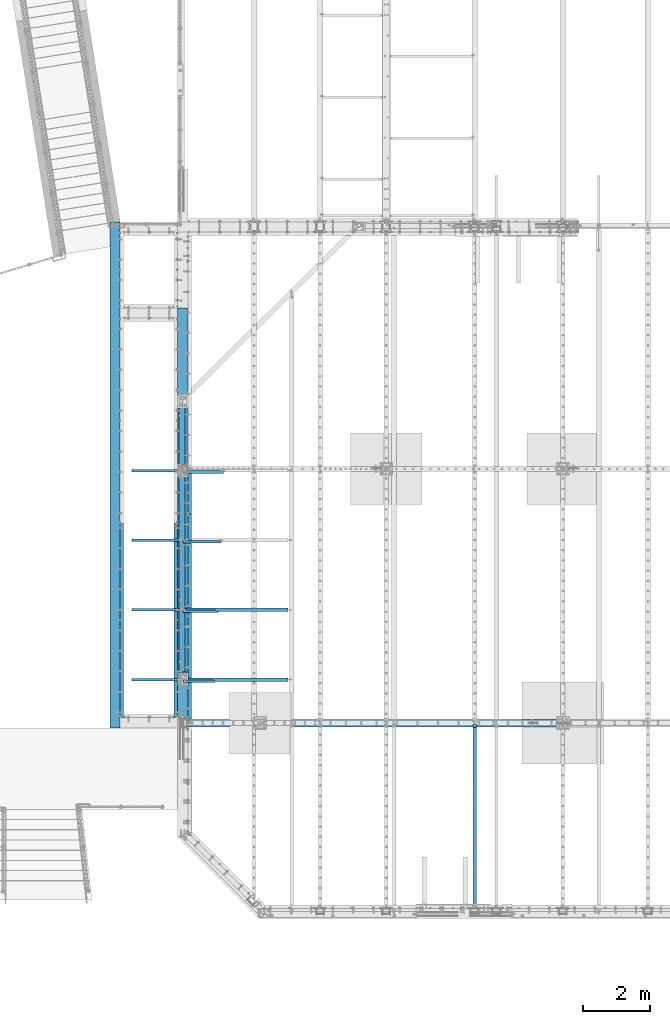
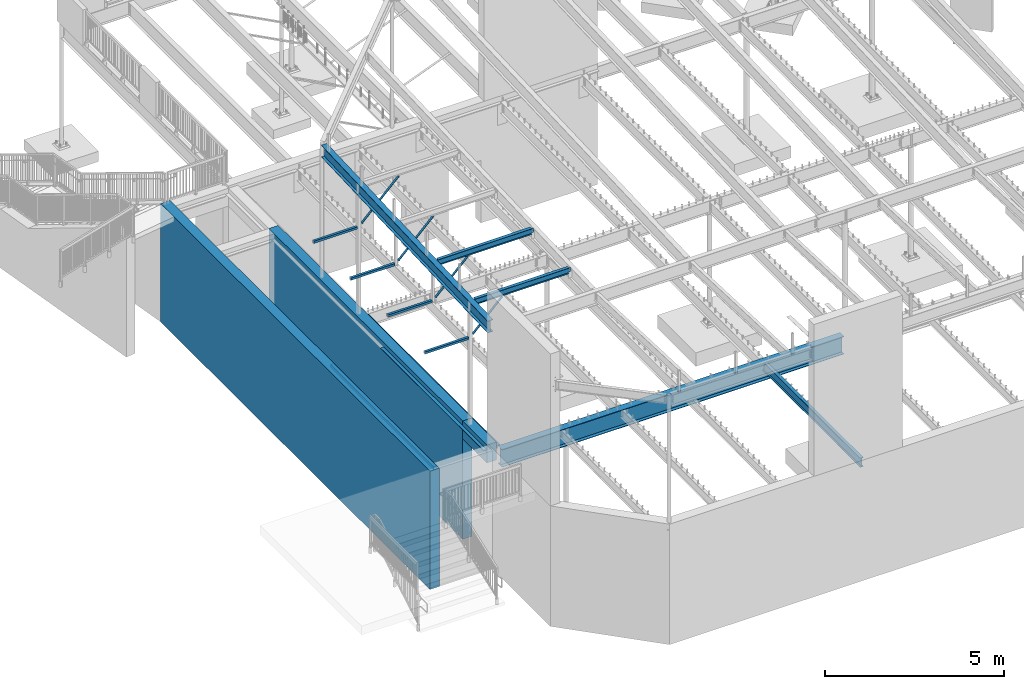
# One storey, part 311 of 975: 16 beams, 4 members.
"""IFC2X3 building model written with IfcOpenShell, lengths in millimetres."""

from ifc_helpers import new_model, si_unit, frame, origin_with_axes, place, context, subcontext, project, spatial, faceted_brep, material, type_object, element, save


model = new_model("IFC2X3")

# Units and contexts
model_context = context("Model", 3, precision=1e-05, world=origin_with_axes())
body_context = subcontext(model_context, "Body", "Model", "MODEL_VIEW")
ifc_project = project(units=[si_unit("LENGTHUNIT", "METRE", prefix="MILLI"), si_unit("AREAUNIT", "SQUARE_METRE"), si_unit("VOLUMEUNIT", "CUBIC_METRE"), si_unit("MASSUNIT", "GRAM", prefix="KILO"), si_unit("TIMEUNIT", "SECOND"), si_unit("PLANEANGLEUNIT", "RADIAN"), si_unit("SOLIDANGLEUNIT", "STERADIAN"), si_unit("THERMODYNAMICTEMPERATUREUNIT", "DEGREE_CELSIUS"), si_unit("LUMINOUSINTENSITYUNIT", "LUMEN")], contexts=[model_context])

# Site, building, storey
site_placement = place(None, origin_with_axes())
site = spatial("IfcSite", under=ifc_project, at=site_placement, CompositionType="ELEMENT")
building_placement = place(site_placement, origin_with_axes())
building = spatial("IfcBuilding", under=site, at=building_placement, Name="Undefined", CompositionType="ELEMENT")
storey_placement = place(building_placement, origin_with_axes())
storey = spatial("IfcBuildingStorey", under=building, at=storey_placement, Name="Undefined", CompositionType="ELEMENT", Elevation=0.0)

# Beams
ifc_material_1 = material(Name="CONCRETE/5000")
beam_type_1 = type_object("IfcBeamType", PredefinedType="NOTDEFINED")
beam_1_placement = place(storey_placement, frame((152.400000017972, 20748.6250000414, 2019.3), z_axis=(0.0, 0.0, 1.0), x_axis=(0.0, -1.0, 0.0)))
element("IfcBeam", 1, at=beam_1_placement, inside=storey, type_object=beam_type_1, material=ifc_material_1, Name="WALL", context=body_context, shape_type="Brep", body=[
    faceted_brep([(0.0, 152.4, -2019.3), (0.0, 152.4, 2019.3), (15072.8519383796, 152.4, 2019.3), (15072.8519383796, 152.4, -2019.3), (0.0, -152.4, 2019.3), (15072.8519383796, -152.4, 2019.3), (0.0, -152.4, -2019.3), (15072.8519383796, -152.4, -2019.3)], [[[0, 1, 2, 3]], [[1, 4, 5, 2]], [[4, 6, 7, 5]], [[6, 0, 3, 7]], [[5, 7, 3, 2]], [[6, 4, 1, 0]]]),
])
beam_2_placement = place(storey_placement, frame((2168.525, 18183.225, 2019.3), z_axis=(0.0, 0.0, 1.0), x_axis=(0.0, -1.0, 0.0)))
element("IfcBeam", 2, at=beam_2_placement, inside=storey, type_object=beam_type_1, material=ifc_material_1, Name="WALL", context=body_context, shape_type="Brep", body=[
    faceted_brep([(0.0, 152.4, -2019.3), (0.0, 152.4, 2019.3), (10839.45, 152.4, 2019.3), (10839.45, 152.4, -2019.3), (0.0, -152.4, 2019.3), (10839.45, -152.4, 2019.3), (0.0, -152.4, -2019.3), (10839.45, -152.4, -2019.3)], [[[0, 1, 2, 3]], [[1, 4, 5, 2]], [[4, 6, 7, 5]], [[6, 0, 3, 7]], [[5, 7, 3, 2]], [[6, 4, 1, 0]]]),
])
ifc_material_2 = material(Name="STEEL/A36")
beam_type_2 = type_object("IfcBeamType", Name="L4X4X5/16", PredefinedType="NOTDEFINED")
for number, where, z_axis, x_axis, name in (
    (3, (355.60003007098, 5994.39980505361, 3835.4), (1.0, 0.0, 0.0), (0.0, 1.0, 0.0), "LEDGER_ANGLE"),
    (4, (1965.32501154889, 11769.7250003556, 3835.4), (-0.999999999999998, 6.90000001668524e-08, 0.0), (0.0, -1.0, 0.0), "LEDGER_ANGLE"),
):
    element("IfcBeam", number, at=place(storey_placement, frame(where, z_axis=z_axis, x_axis=x_axis)), inside=storey, type_object=beam_type_2, material=ifc_material_2, Name=name, ObjectType="L4X4X5/16", context=body_context, shape_type="Brep", body=[
        faceted_brep([(-1.90993887372315e-11, 50.8000000000002, -50.8), (2.00088834390044e-11, 50.8000000000002, 50.8), (5775.32519530204, 50.8000000000002, 50.8000000000993), (5775.325195302, 50.8000000000002, -50.7999999999008), (2.00088834390044e-11, 42.8625000000002, 50.8), (5775.32519530204, 42.8625000000002, 50.8000000000993), (-1.63709046319127e-11, 42.8625000000002, -42.8625), (5775.325195302, 42.8625000000002, -42.8624999999008), (-1.63709046319127e-11, -50.8000000000002, -42.8625), (5775.325195302, -50.8000000000002, -42.8624999999008), (-1.90993887372315e-11, -50.8000000000002, -50.8), (5775.325195302, -50.8000000000002, -50.7999999999008)], [[[0, 1, 2, 3]], [[1, 4, 5, 2]], [[4, 6, 7, 5]], [[6, 8, 9, 7]], [[8, 10, 11, 9]], [[10, 0, 3, 11]], [[5, 7, 9, 11, 3, 2]], [[10, 8, 6, 4, 1, 0]]]),
    ])
beam_3_placement = place(storey_placement, frame((2371.72537068116, 12042.7750061875, 3886.2), z_axis=(1.0, 0.0, 0.0), x_axis=(0.0, 1.0, 0.0)))
element("IfcBeam", 5, at=beam_3_placement, inside=storey, type_object=beam_type_2, material=ifc_material_2, Name="LEDGER_ANGLE", ObjectType="L4X4X5/16", context=body_context, shape_type="Brep", body=[
    faceted_brep([(-1.90993887372315e-11, 50.8000000000002, -50.8), (2.00088834390044e-11, 50.8000000000002, 50.8), (1260.4749999992, 50.8000000000002, 50.7999999999065), (1260.47499999924, 50.8000000000002, -50.8000000000939), (2.00088834390044e-11, 42.8625000000002, 50.8), (1260.4749999992, 42.8625000000002, 50.7999999999065), (-1.63709046319127e-11, 42.8625000000002, -42.8625), (1260.47499999924, 42.8625000000002, -42.8625000000939), (-1.63709046319127e-11, -50.8000000000002, -42.8625), (1260.47499999924, -50.8000000000002, -42.8625000000939), (-1.90993887372315e-11, -50.8000000000002, -50.8), (1260.47499999924, -50.8000000000002, -50.8000000000939)], [[[0, 1, 2, 3]], [[1, 4, 5, 2]], [[4, 6, 7, 5]], [[6, 8, 9, 7]], [[8, 10, 11, 9]], [[10, 0, 3, 11]], [[5, 7, 9, 11, 3, 2]], [[10, 8, 6, 4, 1, 0]]]),
])
beam_4_placement = place(storey_placement, frame((2371.72501101716, 5946.77499700093, 3886.2), z_axis=(1.0, 0.0, 0.0), x_axis=(0.0, 1.0, 0.0)))
element("IfcBeam", 6, at=beam_4_placement, inside=storey, type_object=beam_type_2, material=ifc_material_2, Name="LEDGER_ANGLE", ObjectType="L4X4X5/16", context=body_context, shape_type="Brep", body=[
    faceted_brep([(-1.90993887372315e-11, 50.8000000000002, -50.8), (2.00088834390044e-11, 50.8000000000002, 50.8), (6095.99999999997, 50.8000000000002, 50.8000000001048), (6096.00000000003, 50.8000000000002, -50.7999999998952), (2.00088834390044e-11, 42.8625000000002, 50.8), (6095.99999999997, 42.8625000000002, 50.8000000001048), (-1.63709046319127e-11, 42.8625000000002, -42.8625), (6096.00000000003, 42.8625000000002, -42.8624999998952), (-1.63709046319127e-11, -50.8000000000002, -42.8625), (6096.00000000003, -50.8000000000002, -42.8624999998952), (-1.90993887372315e-11, -50.8000000000002, -50.8), (6096.00000000003, -50.8000000000002, -50.7999999998952)], [[[0, 1, 2, 3]], [[1, 4, 5, 2]], [[4, 6, 7, 5]], [[6, 8, 9, 7]], [[8, 10, 11, 9]], [[10, 0, 3, 11]], [[5, 7, 9, 11, 3, 2]], [[10, 8, 6, 4, 1, 0]]]),
])
ifc_material_3 = material(Name="STEEL/A992")
beam_type_3 = type_object("IfcBeamType", Name="W8X10", PredefinedType="NOTDEFINED")
beam_5_placement = place(storey_placement, frame((2143.16873967635, 7115.17500010167, 8181.14825487244), z_axis=(0.00043655899987343, 0.0, -0.999999904708115), x_axis=(0.999999904708115, 0.0, 0.000436558999873341)))
element("IfcBeam", 7, at=beam_5_placement, inside=storey, type_object=beam_type_3, material=ifc_material_3, Name="BEAM", ObjectType="W8X10", context=body_context, shape_type="Brep", body=[
    faceted_brep([(3152.68790786515, -2.38125000000036, -95.2500000011923), (3152.68790786515, -50.8000000000002, -95.2500000011923), (3152.68790786516, -50.8000000000002, -100.012499998263), (3152.68790786516, 50.8000000000002, -100.012500001189), (3152.68790786515, 50.8000000000002, -95.2500000011923), (3152.68790786515, 2.38125000000036, -95.2500000011923), (3152.68790786515, 2.38125000000036, -87.3124998263784), (3152.68790786515, -2.38125000000036, -87.3124998263784), (3153.65463778774, 2.38125000000036, -82.4524203083338), (3153.65463778774, -2.38125000000036, -82.4524203083338), (3156.40765168821, 2.38125000000036, -78.3322438401801), (3156.40765168821, -2.38125000000036, -78.3322438401801), (3160.52782815637, 2.38125000000036, -75.5792299397044), (3160.52782815637, -2.38125000000036, -75.5792299397044), (3165.38790767441, 2.38125000000036, -74.6125000171169), (3165.38790767441, -2.38125000000036, -74.6125000171169), (3241.66414198657, -2.38125000000036, -74.6125000170896), (3241.66414198657, 2.38125000000036, -74.6125000170896), (3152.68790786629, 50.8000000000002, 95.2499999987285), (3152.68790786629, 2.38125000000036, 95.2499999987285), (118.268769591082, 2.38125000000036, 95.2499999999136), (118.268769591082, 50.8000000000002, 95.2499999999136), (118.268769590937, -2.38125000000036, -87.312499810695), (118.268769590937, 2.38125000000036, -87.312499810695), (118.268769590941, 2.38125000000036, -95.2500000000064), (118.268769590941, 50.8000000000002, -95.2500000000064), (118.268769590944, 50.8000000000002, -100.012500000005), (118.268769590943, -50.8000000000002, -100.012499810899), (118.268769590941, -50.8000000000002, -95.2500000000064), (118.268769590941, -2.38125000000036, -95.2500000000064), (117.302039668346, -2.38125000000036, -82.4524202926505), (117.302039668346, 2.38125000000036, -82.4524202926505), (114.549025767866, -2.38125000000036, -78.3322438245004), (114.549025767866, 2.38125000000036, -78.3322438245004), (110.42884929971, -2.38125000000036, -75.5792299240211), (110.42884929971, 2.38125000000036, -75.5792299240211), (105.568769781664, -2.38125000000036, -74.6125000014354), (105.568769781664, 2.38125000000036, -74.6125000014354), (29.3576807630479, -2.38125000000036, -74.6125000014426), (29.3576807820982, 2.38125000000036, -74.6125000014426), (29.2925352400166, -2.38125000000036, 74.6124999982831), (29.2925352590664, 2.38125000000036, 74.612499998284), (105.568769781842, -2.38125000000036, 74.6124999982885), (105.568769781842, 2.38125000000036, 74.6124999982885), (110.428849299887, -2.38125000000036, 75.5792299208715), (110.428849299887, 2.38125000000036, 75.5792299208715), (114.54902576804, -2.38125000000036, 78.3322438213418), (114.54902576804, 2.38125000000036, 78.3322438213418), (117.302039668516, -2.38125000000036, 82.4524202894881), (117.302039668516, 2.38125000000036, 82.4524202894881), (118.268769591102, -2.38125000000036, 87.3124998075264), (118.268769591102, 2.38125000000036, 87.3124998075264), (3152.68790786629, -50.8000000000002, 100.012499998726), (3152.68790786629, 50.8000000000002, 100.012499998726), (118.268769591083, 50.8000000000002, 100.012499999913), (118.268769591084, -50.8000000000002, 100.012499999913), (3152.68790786629, -50.8000000000002, 95.2499999987285), (118.268769591082, -50.8000000000002, 95.2499999999136), (3152.68790786629, -2.38125000000036, 95.2499999987285), (118.268769591082, -2.38125000000036, 95.2499999999136), (3152.6879078663, -2.38125000000036, 87.3124997917321), (3152.6879078663, 2.38125000000036, 87.3124997917321), (3153.65463778889, -2.38125000000036, 82.4524202736911), (3153.65463778889, 2.38125000000036, 82.4524202736911), (3156.40765168937, -2.38125000000036, 78.3322438055402), (3156.40765168937, 2.38125000000036, 78.3322438055402), (3160.52782815752, -2.38125000000036, 75.5792299050618), (3160.52782815752, 2.38125000000036, 75.5792299050618), (3165.38790767556, -2.38125000000036, 74.6124999824715), (3165.38790767556, 2.38125000000036, 74.6124999824715), (3241.59899646353, -2.38125000000036, 74.6124999824424), (3241.59899646353, 2.38125000000036, 74.6124999824424)], [[[0, 1, 2, 3, 4, 5, 6, 7]], [[7, 6, 8, 9]], [[9, 8, 10, 11]], [[11, 10, 12, 13]], [[13, 12, 14, 15]], [[16, 15, 14, 17]], [[18, 19, 20, 21]], [[22, 23, 24, 25, 26, 27, 28, 29]], [[30, 31, 23, 22]], [[32, 33, 31, 30]], [[34, 35, 33, 32]], [[36, 37, 35, 34]], [[38, 39, 37, 36]], [[40, 41, 39, 38]], [[42, 43, 41, 40]], [[44, 45, 43, 42]], [[46, 47, 45, 44]], [[48, 49, 47, 46]], [[50, 51, 49, 48]], [[52, 53, 54, 55]], [[56, 52, 55, 57]], [[58, 56, 57, 59]], [[55, 54, 21, 20, 51, 50, 59, 57]], [[53, 18, 21, 54]], [[52, 56, 58, 60, 61, 19, 18, 53]], [[62, 63, 61, 60]], [[64, 65, 63, 62]], [[66, 67, 65, 64]], [[68, 69, 67, 66]], [[70, 71, 69, 68]], [[71, 70, 16, 17]], [[12, 10, 8, 6, 5, 24, 23, 31, 33, 35, 37, 39, 41, 43, 45, 47, 49, 51, 20, 19, 61, 63, 65, 67, 69, 71, 17, 14]], [[25, 24, 5, 4]], [[26, 25, 4, 3]], [[27, 26, 3, 2]], [[28, 27, 2, 1]], [[29, 28, 1, 0]], [[70, 68, 66, 64, 62, 60, 58, 59, 50, 48, 46, 44, 42, 40, 38, 36, 34, 32, 30, 22, 29, 0, 7, 9, 11, 13, 15, 16]]]),
])
beam_6_placement = place(storey_placement, frame((2143.23869058687, 9190.56666676833, 8263.7550268726), z_axis=(0.00113598099974151, 0.0, -0.999999354773376), x_axis=(0.999999354773376, 0.0, 0.00113598099974115)))
element("IfcBeam", 8, at=beam_6_placement, inside=storey, type_object=beam_type_3, material=ifc_material_3, Name="BEAM", ObjectType="W8X10", context=body_context, shape_type="Brep", body=[
    faceted_brep([(3152.54978858592, -2.38125000000036, -95.2499999995871), (3152.54978858592, -50.7999999999993, -95.2499999995871), (3152.54978858592, -50.7999999999993, -100.012499996652), (3152.54978858592, 50.7999999999993, -100.012499999588), (3152.54978858592, 50.7999999999993, -95.2499999995871), (3152.54978858592, 2.38125000000036, -95.2499999995871), (3152.54978858592, 2.38125000000036, -87.3124997948671), (3152.54978858592, -2.38125000000036, -87.3124997948671), (3153.51651850851, 2.38125000000036, -82.4524202768189), (3153.51651850851, -2.38125000000036, -82.4524202768189), (3156.26953240898, 2.38125000000036, -78.3322438086616), (3156.26953240898, -2.38125000000036, -78.3322438086616), (3160.38970887714, 2.38125000000036, -75.5792299081822), (3160.38970887714, -2.38125000000036, -75.5792299081822), (3165.24978839519, 2.38125000000036, -74.6124999855929), (3165.24978839519, -2.38125000000036, -74.6124999855929), (3241.44978858411, -2.38125000000036, -74.612499985582), (3241.44978858411, 2.38125000000036, -74.612499985582), (3152.54978858586, 50.7999999999993, 95.2500000004438), (3152.54978858586, 2.38125000000036, 95.2500000004438), (118.268769591082, 2.38125000000036, 95.2499999999136), (118.268769591082, 50.8000000000002, 95.2499999999136), (118.268769590937, -2.38125000000036, -87.312499810695), (118.268769590937, 2.38125000000036, -87.312499810695), (118.268769590941, 2.38125000000036, -95.2500000000064), (118.268769590941, 50.8000000000002, -95.2500000000064), (118.268769590944, 50.8000000000002, -100.012500000005), (118.268769590943, -50.8000000000002, -100.012499810899), (118.268769590941, -50.8000000000002, -95.2500000000064), (118.268769590941, -2.38125000000036, -95.2500000000064), (117.302039668346, -2.38125000000036, -82.4524202926505), (117.302039668346, 2.38125000000036, -82.4524202926505), (114.549025767866, -2.38125000000036, -78.3322438245004), (114.549025767866, 2.38125000000036, -78.3322438245004), (110.42884929971, -2.38125000000036, -75.5792299240211), (110.42884929971, 2.38125000000036, -75.5792299240211), (105.568769781664, -2.38125000000036, -74.6125000014354), (105.568769781664, 2.38125000000036, -74.6125000014354), (29.3687774666446, -2.38125000000036, -74.6125000038883), (29.3687774666446, 2.38125000000036, -74.6125000038883), (29.3687774666446, -2.38125000000036, 74.6124999961967), (29.3687774666446, 2.38125000000036, 74.6124999961967), (105.568769781842, -2.38125000000036, 74.6124999982885), (105.568769781842, 2.38125000000036, 74.6124999982885), (110.428849299887, -2.38125000000036, 75.5792299208715), (110.428849299887, 2.38125000000036, 75.5792299208715), (114.54902576804, -2.38125000000036, 78.3322438213418), (114.54902576804, 2.38125000000036, 78.3322438213418), (117.302039668516, -2.38125000000036, 82.4524202894881), (117.302039668516, 2.38125000000036, 82.4524202894881), (118.268769591102, -2.38125000000036, 87.3124998075264), (118.268769591102, 2.38125000000036, 87.3124998075264), (3152.54978858586, -50.7999999999993, 100.012500000444), (3152.54978858586, 50.7999999999993, 100.012500000444), (118.268769591083, 50.8000000000002, 100.012499999913), (118.268769591084, -50.8000000000002, 100.012499999913), (3152.54978858586, -50.7999999999993, 95.2500000004438), (118.268769591082, -50.8000000000002, 95.2499999999136), (3152.54978858586, -2.38125000000036, 95.2500000004438), (118.268769591082, -2.38125000000036, 95.2499999999136), (3152.54978858586, -2.38125000000036, 87.312499823769), (3152.54978858586, 2.38125000000036, 87.312499823769), (3153.51651850845, -2.38125000000036, 82.4524203057217), (3153.51651850845, 2.38125000000036, 82.4524203057217), (3156.26953240893, -2.38125000000036, 78.3322438375671), (3156.26953240893, 2.38125000000036, 78.3322438375671), (3160.38970887709, -2.38125000000036, 75.5792299370878), (3160.38970887709, 2.38125000000036, 75.5792299370878), (3165.24978839514, -2.38125000000036, 74.6125000144993), (3165.24978839514, 2.38125000000036, 74.6125000144993), (3241.44978858411, -2.38125000000036, 74.6125000145094), (3241.44978858411, 2.38125000000036, 74.6125000145094)], [[[0, 1, 2, 3, 4, 5, 6, 7]], [[7, 6, 8, 9]], [[9, 8, 10, 11]], [[11, 10, 12, 13]], [[13, 12, 14, 15]], [[16, 15, 14, 17]], [[18, 19, 20, 21]], [[22, 23, 24, 25, 26, 27, 28, 29]], [[30, 31, 23, 22]], [[32, 33, 31, 30]], [[34, 35, 33, 32]], [[36, 37, 35, 34]], [[38, 39, 37, 36]], [[40, 41, 39, 38]], [[42, 43, 41, 40]], [[44, 45, 43, 42]], [[46, 47, 45, 44]], [[48, 49, 47, 46]], [[50, 51, 49, 48]], [[52, 53, 54, 55]], [[56, 52, 55, 57]], [[58, 56, 57, 59]], [[55, 54, 21, 20, 51, 50, 59, 57]], [[53, 18, 21, 54]], [[52, 56, 58, 60, 61, 19, 18, 53]], [[62, 63, 61, 60]], [[64, 65, 63, 62]], [[66, 67, 65, 64]], [[68, 69, 67, 66]], [[70, 71, 69, 68]], [[71, 70, 16, 17]], [[12, 10, 8, 6, 5, 24, 23, 31, 33, 35, 37, 39, 41, 43, 45, 47, 49, 51, 20, 19, 61, 63, 65, 67, 69, 71, 17, 14]], [[25, 24, 5, 4]], [[26, 25, 4, 3]], [[27, 26, 3, 2]], [[28, 27, 2, 1]], [[29, 28, 1, 0]], [[70, 68, 66, 64, 62, 60, 58, 59, 50, 48, 46, 44, 42, 40, 38, 36, 34, 32, 30, 22, 29, 0, 7, 9, 11, 13, 15, 16]]]),
])

# Members
member_type = type_object("IfcMemberType", Name="L3X3X3/8", PredefinedType="NOTDEFINED")
member_1_placement = place(storey_placement, frame((2113.23487193955, 7072.31249999981, 7002.1901279931), z_axis=(0.0, -1.0, 0.0), x_axis=(0.707106781186555, 0.0, 0.70710678118654)))
element("IfcMember", 9, at=member_1_placement, inside=storey, type_object=member_type, material=ifc_material_2, Name="ANGLE", ObjectType="L3X3X3/8", context=body_context, shape_type="Brep", body=[
    faceted_brep([(134.252563368805, 38.1000000000063, -38.1000000000004), (134.252563368805, 38.1000000000063, 38.1000000000004), (1470.40581651214, 38.1000000000063, 38.1000000000004), (1470.40581651214, 38.1000000000063, -38.1000000000004), (134.252563368805, 28.5750000000044, 38.1000000000004), (1470.40581651214, 28.5750000000048, 38.1000000000004), (134.252563368805, 28.5750000000044, -28.5749999999998), (1470.40581651214, 28.5750000000048, -28.5749999999998), (134.252563368806, -38.1000000000063, -28.5749999999998), (1470.40581651214, -38.1000000000067, -28.5749999999998), (134.252563368806, -38.1000000000063, -38.1000000000004), (1470.40581651214, -38.1000000000067, -38.1000000000004)], [[[0, 1, 2, 3]], [[1, 4, 5, 2]], [[4, 6, 7, 5]], [[6, 8, 9, 7]], [[8, 10, 11, 9]], [[10, 0, 3, 11]], [[5, 7, 9, 11, 3, 2]], [[10, 8, 6, 4, 1, 0]]]),
])
member_2_placement = place(storey_placement, frame((2113.2348699381, 9147.70416664806, 7002.1901279966), z_axis=(0.0, -1.0, 0.0), x_axis=(0.707106781186555, 0.0, 0.70710678118654)))
element("IfcMember", 10, at=member_2_placement, inside=storey, type_object=member_type, material=ifc_material_2, Name="ANGLE", ObjectType="L3X3X3/8", context=body_context, shape_type="Brep", body=[
    faceted_brep([(116.292052598414, 38.1000000000186, -38.0999999999403), (116.292051669375, 38.0999999999958, 38.1000000000604), (1588.33537838559, 38.1000000000067, 38.1000000007753), (1588.33537931463, 38.1000000000295, -38.0999999992237), (116.292051676107, 28.5749999999944, 38.1000000000586), (1588.33537838559, 28.5750000000053, 38.1000000007753), (116.292052489016, 28.5750000000139, -28.5749999999407), (1588.3353791985, 28.5750000000248, -28.5749999992258), (116.292052536141, -38.0999999999972, -28.5749999999498), (1588.33537919847, -38.0999999999872, -28.5749999992313), (116.292052652271, -38.0999999999949, -38.0999999999494), (1588.33537931461, -38.0999999999835, -38.0999999992309)], [[[0, 1, 2, 3]], [[1, 4, 5, 2]], [[4, 6, 7, 5]], [[6, 8, 9, 7]], [[8, 10, 11, 9]], [[10, 0, 3, 11]], [[5, 7, 9, 11, 3, 2]], [[10, 8, 6, 4, 1, 0]]]),
])
member_3_placement = place(storey_placement, frame((2113.2348720069, 11223.0958333332, 7002.1901279931), z_axis=(0.0, -1.0, 0.0), x_axis=(0.707106781186555, 0.0, 0.70710678118654)))
element("IfcMember", 11, at=member_3_placement, inside=storey, type_object=member_type, material=ifc_material_2, Name="ANGLE", ObjectType="L3X3X3/8", context=body_context, shape_type="Brep", body=[
    faceted_brep([(116.292052598414, 38.1000000000186, -38.0999999999403), (116.292051669375, 38.0999999999958, 38.1000000000604), (1706.43006050504, 38.1000000000099, 38.1000000000004), (1706.43006050504, 38.1000000000099, -38.1000000000004), (116.292051676107, 28.5749999999944, 38.1000000000586), (1706.43006050504, 28.5750000000075, 38.1000000000004), (116.292052489016, 28.5750000000139, -28.5749999999407), (1706.43006050504, 28.5750000000075, -28.5750000000007), (116.292052536141, -38.0999999999972, -28.5749999999498), (1706.43006050504, -38.1000000000045, -28.5750000000007), (116.292052652271, -38.0999999999949, -38.0999999999494), (1706.43006050504, -38.1000000000045, -38.1000000000004)], [[[0, 1, 2, 3]], [[1, 4, 5, 2]], [[4, 6, 7, 5]], [[6, 8, 9, 7]], [[8, 10, 11, 9]], [[10, 0, 3, 11]], [[5, 7, 9, 11, 3, 2]], [[10, 8, 6, 4, 1, 0]]]),
])
member_4_placement = place(storey_placement, frame((2113.23487269252, 13298.4874999192, 7002.1901279931), z_axis=(0.0, -1.0, 0.0), x_axis=(0.707106781186555, 0.0, 0.70710678118654)))
element("IfcMember", 12, at=member_4_placement, inside=storey, type_object=member_type, material=ifc_material_2, Name="ANGLE", ObjectType="L3X3X3/8", context=body_context, shape_type="Brep", body=[
    faceted_brep([(134.252563368805, 38.1000000000063, -38.1000000000004), (134.252563368805, 38.1000000000063, 38.1000000000004), (1824.69020641276, 38.100000000024, 38.0999999994056), (1824.69021058239, 38.099999999989, -38.1000000005952), (134.252563368805, 28.5750000000044, 38.1000000000004), (1824.69020641276, 28.5750000000212, 38.0999999994092), (134.252563368805, 28.5750000000044, -28.5749999999998), (1824.69021006118, 28.5749999999907, -28.5750000005901), (134.252563368806, -38.1000000000063, -28.5749999999998), (1824.69021006119, -38.1000000000195, -28.575000000561), (134.252563368806, -38.1000000000063, -38.1000000000004), (1824.69021058239, -38.100000000024, -38.1000000005606)], [[[0, 1, 2, 3]], [[1, 4, 5, 2]], [[4, 6, 7, 5]], [[6, 8, 9, 7]], [[8, 10, 11, 9]], [[10, 0, 3, 11]], [[5, 7, 9, 11, 3, 2]], [[10, 8, 6, 4, 1, 0]]]),
])

# Beams
ifc_material_4 = material()
beam_type_4 = type_object("IfcBeamType", Name="HSS3X3X1/4", PredefinedType="NOTDEFINED")
for number, where, z_axis, x_axis in (
    (13, (669.925, 13341.3499999996, 6997.7), (0.0, 0.0, -1.0), (1.0, 0.0, 0.0)),
    (14, (669.924997752038, 7115.175, 6997.7), (0.0, 0.0, -1.0), (1.0, 0.0, 0.0)),
):
    element("IfcBeam", number, at=place(storey_placement, frame(where, z_axis=z_axis, x_axis=x_axis)), inside=storey, type_object=beam_type_4, material=ifc_material_4, ObjectType="HSS3X3X1/4", context=body_context, shape_type="Brep", body=[
        faceted_brep([(-19.0500000000239, 31.7500000000146, -31.75), (-19.0499999999805, -31.7499999999836, -31.75), (1396.99999999843, -31.7500000009441, -31.75), (1396.99999999843, 31.7499999990559, -31.75), (-19.0499999999805, -31.7499999999836, 31.75), (1396.99999999843, -31.7500000009441, 31.75), (-19.0500000000239, 31.7500000000146, 31.75), (1396.99999999843, 31.7499999990559, 31.75), (-19.0500000000283, 38.1000000000149, -38.1000000000004), (-19.0500000000283, 38.1000000000149, 38.1000000000004), (1396.99999999843, 38.0999999990563, 38.1000000000004), (1396.99999999843, 38.0999999990563, -38.1000000000004), (-19.0499999999762, -38.099999999984, 38.1000000000004), (1396.99999999843, -38.1000000009444, 38.1000000000004), (-19.0499999999762, -38.099999999984, -38.1000000000004), (1396.99999999843, -38.1000000009444, -38.1000000000004)], [[[0, 1, 2, 3]], [[1, 4, 5, 2]], [[4, 6, 7, 5]], [[6, 0, 3, 7]], [[8, 9, 10, 11]], [[9, 12, 13, 10]], [[12, 14, 15, 13]], [[14, 8, 11, 15]], [[13, 15, 11, 10], [5, 7, 3, 2]], [[14, 12, 9, 8], [6, 4, 1, 0]]]),
    ])
for number, where, z_axis, x_axis, name in (
    (15, (669.924997752038, 11265.9583333333, 6997.7), (0.0, 0.0, -1.0), (1.0, 0.0, 0.0), "FRAME"),
    (16, (669.924997752038, 9190.56675883314, 6997.7), (0.0, 0.0, -1.0), (1.0, 0.0, 0.0), "FRAME"),
):
    element("IfcBeam", number, at=place(storey_placement, frame(where, z_axis=z_axis, x_axis=x_axis)), inside=storey, type_object=beam_type_4, material=ifc_material_4, Name=name, ObjectType="HSS3X3X1/4", context=body_context, shape_type="Brep", body=[
        faceted_brep([(-19.0500000000239, 31.7500000000146, -31.75), (-19.0499999999805, -31.7499999999836, -31.75), (1409.7, -31.750000000955, -31.75), (1409.7, 31.749999999045, -31.75), (-19.0499999999805, -31.7499999999836, 31.75), (1409.7, -31.750000000955, 31.75), (-19.0500000000239, 31.7500000000146, 31.75), (1409.7, 31.749999999045, 31.75), (-19.0500000000283, 38.1000000000149, -38.1000000000004), (-19.0500000000283, 38.1000000000149, 38.1000000000004), (1409.7, 38.0999999990454, 38.1000000000004), (1409.7, 38.0999999990454, -38.1000000000004), (-19.0499999999762, -38.099999999984, 38.1000000000004), (1409.7, -38.1000000009553, 38.1000000000004), (-19.0499999999762, -38.099999999984, -38.1000000000004), (1409.7, -38.1000000009553, -38.1000000000004)], [[[0, 1, 2, 3]], [[1, 4, 5, 2]], [[4, 6, 7, 5]], [[6, 0, 3, 7]], [[8, 9, 10, 11]], [[9, 12, 13, 10]], [[12, 14, 15, 13]], [[14, 8, 11, 15]], [[13, 15, 11, 10], [5, 7, 3, 2]], [[14, 12, 9, 8], [6, 4, 1, 0]]]),
    ])
beam_type_5 = type_object("IfcBeamType", Name="W16X36", PredefinedType="NOTDEFINED")
beam_7_placement = place(storey_placement, frame((2143.12510009499, 5827.79342367029, 8028.14701531603), z_axis=(0.0, -0.0397714610178109, 0.999208802447471), x_axis=(0.0, 0.999208802447471, 0.0397714610178109)))
element("IfcBeam", 17, at=beam_7_placement, inside=storey, type_object=beam_type_5, material=ifc_material_3, Name="BEAM", ObjectType="W16X36", context=body_context, shape_type="Brep", body=[
    faceted_brep([(171.411012249427, -88.9000000000069, -201.612499999929), (171.411012960548, 88.8999999999933, -201.612499999939), (9487.89495226353, 88.899999999599, -201.612499997548), (9487.89495155241, -88.9000000004012, -201.612499997538), (171.847509798187, -88.9000000000069, -190.499999999929), (171.847510137874, -3.96875000000682, -190.499999999935), (186.813140381115, -3.96875000000773, 190.500000000029), (186.813140041428, -88.9000000000074, 190.500000000035), (187.249637590189, -88.9000000000078, 201.612500000032), (187.24963830131, 88.8999999999924, 201.612500000023), (186.81314075255, 88.8999999999924, 190.500000000023), (186.813140412862, 3.96874999999227, 190.500000000029), (171.847510169622, 3.96874999999318, -190.499999999935), (171.847510509308, 88.8999999999928, -190.49999999994), (9488.33726186781, -88.9000000004012, -190.49999999754), (9488.3372622075, -3.96875000040109, -190.499999997545), (9503.50218730691, -3.968750000402, 190.500000002418), (9503.50218696722, -88.9000000004021, 190.500000002424), (9503.94449728262, -88.9000000004021, 201.612500002423), (9503.94449799374, 88.8999999995981, 201.612500002414), (9503.50218767834, 88.8999999995981, 190.500000002413), (9503.50218733865, 3.968749999598, 190.500000002418), (9488.33726223925, 3.96874999959891, -190.499999997545), (9488.33726257893, 88.8999999995985, -190.499999997551)], [[[0, 1, 2, 3]], [[0, 4, 5, 6, 7, 8, 9, 10, 11, 12, 13, 1]], [[5, 4, 14, 15]], [[6, 5, 15, 16]], [[7, 6, 16, 17]], [[8, 7, 17, 18]], [[9, 8, 18, 19]], [[10, 9, 19, 20]], [[11, 10, 20, 21]], [[12, 11, 21, 22]], [[13, 12, 22, 23]], [[1, 13, 23, 2]], [[22, 21, 20, 19, 18, 17, 16, 15, 14, 3, 2, 23]], [[4, 0, 3, 14]]]),
])
beam_type_6 = type_object("IfcBeamType", PredefinedType="NOTDEFINED")
beam_8_placement = place(storey_placement, frame((2168.525, 7343.77501120331, 3733.8), z_axis=(0.0, 0.0, 1.0), x_axis=(0.0, -1.0, 0.0)))
element("IfcBeam", 18, at=beam_8_placement, inside=storey, type_object=beam_type_6, material=ifc_material_1, Name="WALL", context=body_context, shape_type="Brep", body=[
    faceted_brep([(-2.00088834390044e-11, 152.400000000001, -304.8), (-2.00088834390044e-11, 152.400000000001, 304.8), (1362.07460941621, 152.400000000173, 304.8), (1362.07460941621, 152.400000000173, -304.8), (1.90993887372315e-11, -152.400000000001, 304.8), (1362.07460941625, -152.399999999828, 304.8), (1.90993887372315e-11, -152.400000000001, -304.8), (1362.07460941625, -152.399999999828, -304.8)], [[[0, 1, 2, 3]], [[1, 4, 5, 2]], [[4, 6, 7, 5]], [[6, 0, 3, 7]], [[5, 7, 3, 2]], [[6, 4, 1, 0]]]),
])
beam_type_7 = type_object("IfcBeamType", Name="W12X19", PredefinedType="NOTDEFINED")
beam_9_placement = place(storey_placement, frame((10858.5, 114.300000000002, 3783.0125), z_axis=(0.0, 0.0, 1.0), x_axis=(0.0, 1.0, 0.0)))
element("IfcBeam", 19, at=beam_9_placement, inside=storey, type_object=beam_type_7, material=ifc_material_3, Name="BEAM", ObjectType="W12X19", context=body_context, shape_type="Brep", body=[
    faceted_brep([(215.899999999996, -3.17499999999927, -144.4625), (215.899999999996, -50.7999999999993, -144.4625), (5674.51874999999, -50.7999999999993, -144.4625), (5674.51874999999, -3.17499999999927, -144.4625), (215.899999999996, -50.7999999999993, -153.9875), (5674.51874999999, -50.7999999999993, -153.9875), (215.899999999996, 50.7999999999993, -153.9875), (5674.51874999999, 50.7999999999993, -153.9875), (215.899999999996, 50.7999999999993, -144.4625), (215.899999999996, 3.17499999999927, -144.4625), (5674.51874999999, 3.17499999999927, -144.4625), (5674.51874999999, 50.7999999999993, -144.4625), (5674.51874999999, 3.17499999999927, 128.5875), (5674.51874999999, -3.17499999999927, 128.5875), (215.899999999996, -3.17499999999927, 144.4625), (215.899999999996, -50.7999999999993, 144.4625), (215.899999999996, -50.7999999999993, 153.9875), (215.899999999996, 50.7999999999993, 153.9875), (215.899999999996, 50.7999999999993, 144.4625), (215.899999999996, 3.17499999999927, 144.4625), (5572.91875, 50.7999999999993, 144.4625), (5572.91875, 3.17499999999927, 144.4625), (5572.91875, 3.17499999999927, 141.287499809265), (5573.88547992258, 3.17499999999927, 136.42742029122), (5576.63849382306, 3.17499999999927, 132.307243823066), (5580.75867029121, 3.17499999999927, 129.554229922588), (5585.61874980926, 3.17499999999927, 128.5875), (5573.88547992258, -3.17499999999927, 136.42742029122), (5572.91875, -3.17499999999927, 141.287499809265), (5576.63849382306, -3.17499999999927, 132.307243823066), (5580.75867029121, -3.17499999999927, 129.554229922588), (5585.61874980926, -3.17499999999927, 128.5875), (5572.91875, -3.17499999999927, 144.4625), (5572.91875, -50.7999999999993, 144.4625), (5572.91875, -50.7999999999993, 153.9875), (5572.91875, 50.7999999999993, 153.9875)], [[[0, 1, 2, 3]], [[1, 4, 5, 2]], [[4, 6, 7, 5]], [[8, 9, 10, 11]], [[3, 2, 5, 7, 11, 10, 12, 13]], [[6, 8, 11, 7]], [[4, 1, 0, 14, 15, 16, 17, 18, 19, 9, 8, 6]], [[19, 18, 20, 21]], [[10, 9, 19, 21, 22, 23, 24, 25, 26, 12]], [[27, 23, 22, 28]], [[29, 24, 23, 27]], [[30, 25, 24, 29]], [[31, 26, 25, 30]], [[13, 12, 26, 31]], [[30, 29, 27, 28, 32, 14, 0, 3, 13, 31]], [[15, 14, 32, 33]], [[16, 15, 33, 34]], [[17, 16, 34, 35]], [[18, 17, 35, 20]], [[34, 33, 32, 28, 22, 21, 20, 35]]]),
])
beam_type_8 = type_object("IfcBeamType", Name="W24X68", PredefinedType="NOTDEFINED")
beam_10_placement = place(storey_placement, frame((2320.925, 5819.775, 3635.375), z_axis=(0.0, 0.0, 1.0), x_axis=(1.0, 0.0, 0.0)))
element("IfcBeam", 20, at=beam_10_placement, inside=storey, type_object=beam_type_8, material=ifc_material_3, Name="BEAM", ObjectType="W24X68", context=body_context, shape_type="Brep", body=[
    faceted_brep([(25.4000009443685, -114.3, -287.3375), (25.4000009443685, -114.3, -301.625), (11069.574, -114.3, -301.625), (11069.574, -114.3, -287.3375), (25.4000009443685, -5.55624999999964, -287.3375), (11069.574, -5.55624999999964, -287.3375), (25.4000009443685, -5.55624999999964, 287.3375), (11069.574, -5.55624999999964, 287.3375), (25.4000009443685, -114.3, 287.3375), (11069.574, -114.3, 287.3375), (25.4000009443685, -114.3, 301.625), (11069.574, -114.3, 301.625), (25.4000009443685, 114.3, 301.625), (11069.574, 114.3, 301.625), (25.4000009443685, 114.3, 287.3375), (11069.574, 114.3, 287.3375), (25.4000009443685, 5.55624999999964, 287.3375), (11069.574, 5.55624999999964, 287.3375), (25.4000009443685, 5.55624999999964, -287.3375), (11069.574, 5.55624999999964, -287.3375), (25.4000009443685, 114.3, -287.3375), (11069.574, 114.3, -287.3375), (25.4000009443685, 114.3, -301.625), (11069.574, 114.3, -301.625)], [[[0, 1, 2, 3]], [[4, 0, 3, 5]], [[6, 4, 5, 7]], [[8, 6, 7, 9]], [[10, 8, 9, 11]], [[12, 10, 11, 13]], [[14, 12, 13, 15]], [[16, 14, 15, 17]], [[18, 16, 17, 19]], [[20, 18, 19, 21]], [[1, 0, 4, 6, 8, 10, 12, 14, 16, 18, 20, 22]], [[1, 22, 23, 2]], [[19, 17, 15, 13, 11, 9, 7, 5, 3, 2, 23, 21]], [[22, 20, 21, 23]]]),
])

save(model, "model.ifc")
